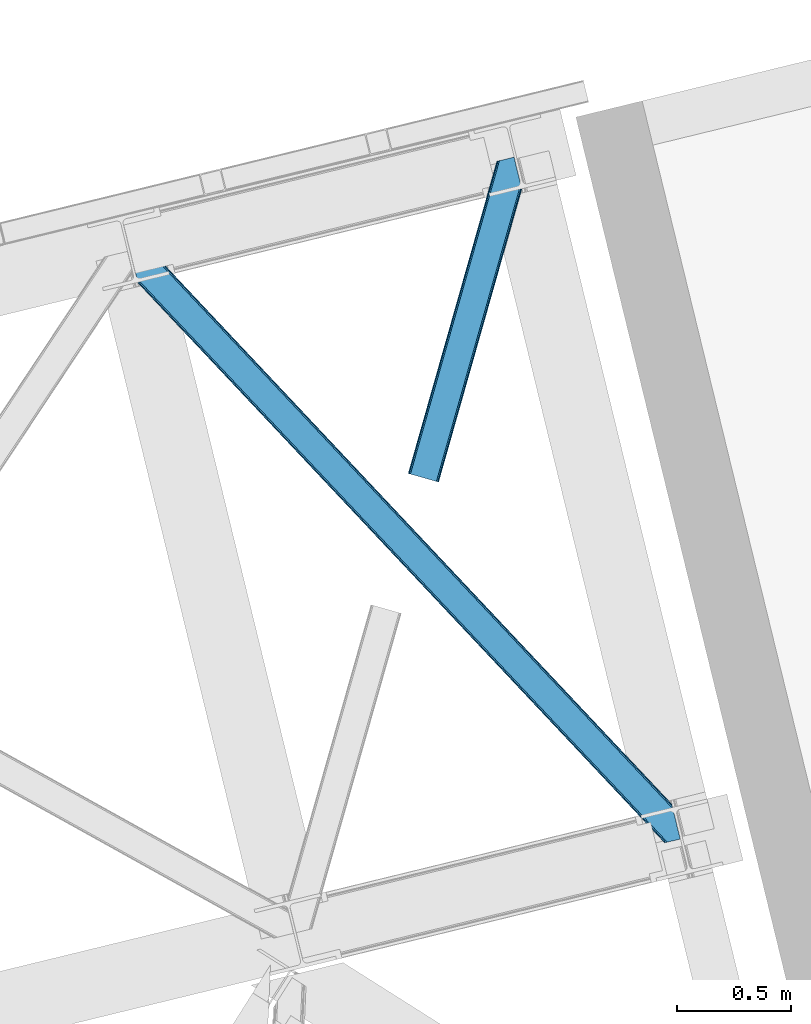
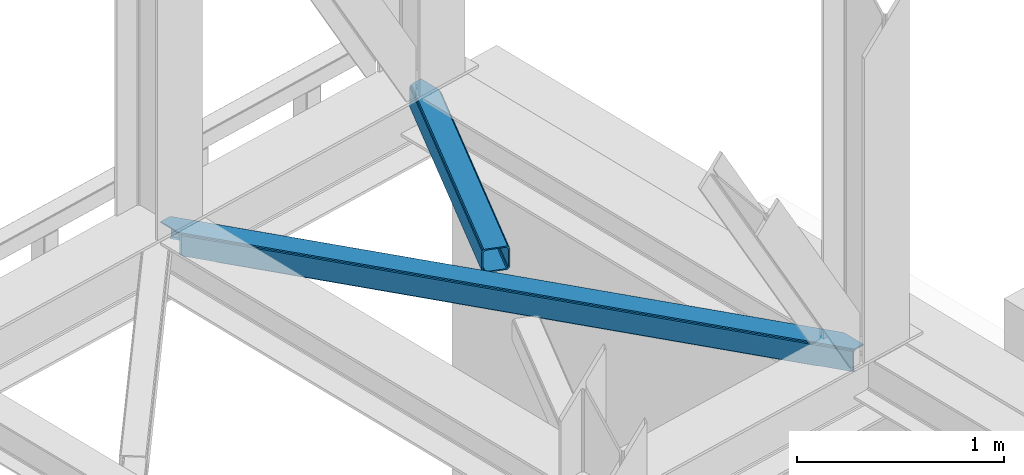
# One storey, part 84 of 93: 2 members.
"""IFC4 building model written with IfcOpenShell, lengths in millimetres."""

from ifc_helpers import new_model, entity, si_unit, converted_unit, derived_unit, direction, frame, origin, place, context, subcontext, project, spatial, triangles, type_object, element, save


model = new_model("IFC4")

# Units and contexts
model_context = context("Model", 3, precision=0.01, world=origin(), true_north=direction((6.12303176911189e-17, 1.0)))
plan_context = context("Plan", 3, precision=0.01, world=origin(), true_north=direction((6.12303176911189e-17, 1.0)))
body_context = subcontext(model_context, "Body", "Model", "MODEL_VIEW")
ifc_project = project(units=[si_unit("LENGTHUNIT", "METRE", prefix="MILLI"), si_unit("AREAUNIT", "SQUARE_METRE"), si_unit("VOLUMEUNIT", "CUBIC_METRE"), converted_unit("PLANEANGLEUNIT", "DEGREE", entity("IfcRatioMeasure", 0.0174532925199433), si_unit("PLANEANGLEUNIT", "RADIAN"), dimensions=[0, 0, 0, 0, 0, 0, 0]), si_unit("MASSUNIT", "GRAM", prefix="KILO"), derived_unit("MASSDENSITYUNIT", [(si_unit("MASSUNIT", "GRAM", prefix="KILO"), 1), (si_unit("LENGTHUNIT", "METRE"), -3)]), derived_unit("MOMENTOFINERTIAUNIT", [(si_unit("LENGTHUNIT", "METRE"), 4)]), si_unit("TIMEUNIT", "SECOND"), si_unit("FREQUENCYUNIT", "HERTZ"), si_unit("THERMODYNAMICTEMPERATUREUNIT", "DEGREE_CELSIUS"), derived_unit("THERMALTRANSMITTANCEUNIT", [(si_unit("MASSUNIT", "GRAM", prefix="KILO"), 1), (si_unit("THERMODYNAMICTEMPERATUREUNIT", "KELVIN"), -1), (si_unit("TIMEUNIT", "SECOND"), -3)]), derived_unit("VOLUMETRICFLOWRATEUNIT", [(si_unit("LENGTHUNIT", "METRE"), 3), (si_unit("TIMEUNIT", "SECOND"), -1)]), derived_unit("MASSFLOWRATEUNIT", [(si_unit("MASSUNIT", "GRAM", prefix="KILO"), 1), (si_unit("TIMEUNIT", "SECOND"), -1)]), derived_unit("ROTATIONALFREQUENCYUNIT", [(si_unit("TIMEUNIT", "SECOND"), -1)]), si_unit("ELECTRICCURRENTUNIT", "AMPERE"), si_unit("ELECTRICVOLTAGEUNIT", "VOLT"), si_unit("POWERUNIT", "WATT"), si_unit("FORCEUNIT", "NEWTON", prefix="KILO"), si_unit("ILLUMINANCEUNIT", "LUX"), si_unit("LUMINOUSFLUXUNIT", "LUMEN"), si_unit("LUMINOUSINTENSITYUNIT", "CANDELA"), derived_unit("USERDEFINED", [(si_unit("MASSUNIT", "GRAM", prefix="KILO"), -1), (si_unit("LENGTHUNIT", "METRE"), -2), (si_unit("TIMEUNIT", "SECOND"), 3), (si_unit("LUMINOUSFLUXUNIT", "LUMEN"), 1)]), derived_unit("LINEARVELOCITYUNIT", [(si_unit("LENGTHUNIT", "METRE"), 1), (si_unit("TIMEUNIT", "SECOND"), -1)]), si_unit("PRESSUREUNIT", "PASCAL"), derived_unit("USERDEFINED", [(si_unit("LENGTHUNIT", "METRE"), -2), (si_unit("MASSUNIT", "GRAM", prefix="KILO"), 1), (si_unit("TIMEUNIT", "SECOND"), -2)]), derived_unit("LINEARFORCEUNIT", [(si_unit("MASSUNIT", "GRAM", prefix="KILO"), 1), (si_unit("LENGTHUNIT", "METRE"), 1), (si_unit("TIMEUNIT", "SECOND"), -2), (si_unit("LENGTHUNIT", "METRE"), -1)]), derived_unit("PLANARFORCEUNIT", [(si_unit("MASSUNIT", "GRAM", prefix="KILO"), 1), (si_unit("LENGTHUNIT", "METRE"), 1), (si_unit("TIMEUNIT", "SECOND"), -2), (si_unit("LENGTHUNIT", "METRE"), -2)])], contexts=[model_context, plan_context])

# Site, building, storey
site_placement = place(None, origin())
site = spatial("IfcSite", under=ifc_project, at=site_placement, CompositionType="ELEMENT")
building_placement = place(site_placement, origin())
building = spatial("IfcBuilding", under=site, at=building_placement, CompositionType="ELEMENT")
storey_placement = place(building_placement, frame((0.0, 0.0, 15900.0)))
storey = spatial("IfcBuildingStorey", under=building, at=storey_placement, CompositionType="ELEMENT", Elevation=15900.0)

# Members
member_type_1 = type_object("IfcMemberType", PredefinedType="BRACE")
member_1_placement = place(storey_placement, frame((-2893.848072052, 17476.1728088379, 3510.01988525391)))
element("IfcMember", 1, at=member_1_placement, inside=storey, type_object=member_type_1, ObjectType="Steel Horizontal Brace", PredefinedType="BRACE", context=body_context, shape_type="Tessellation", body=[
    triangles([(2390.20879182816, 136.983499145506, 140.000756835936), (2386.99318141937, 150.175717163085, 138.668280029298), (56.5227127075195, 2617.59836425781, 140.000756835936), (64.0010353088378, 2619.42150878906, 138.668280029298), (2384.26711235046, 161.358755493166, 134.87548828125), (70.3451248168944, 2620.96792602539, 134.87548828125), (2382.44560289383, 168.831555175781, 129.196765136719), (74.5788780212401, 2622.00042114258, 129.196765136719), (2381.80599803925, 171.455813598634, 122.499499511719), (76.0700660705566, 2622.36318969727, 122.499499511719), (2006.64328708649, 570.234960937501, 17.5000946044929), (2381.80599803925, 171.455813598634, 17.5000946044929), (1617.6124546051, 983.763208007811, 17.5000946044929), (1228.57718925476, 1397.2902923584, 17.5000946044929), (450.510873413086, 2224.3456237793, 17.5000946044929), (76.0700660705566, 2622.36318969727, 17.5000946044929), (839.546284103394, 1810.81853942871, 17.5000946044929), (26.1158477783201, 2496.68248901367, 140.000756835936), (0.0, 2603.82013549805, 140.000756835936), (2370.43223733902, 4.76366271972802, 140.000756835936), (2419.52200984955, 16.7303741455071, 140.000756835936), (2350.88942584991, 0.0, 122.499499511719), (2352.37603569031, 0.362768554688955, 129.196765136719), (34.5188232421874, 2462.2125, 122.499499511719), (33.8790367126462, 2464.83559570312, 129.196765136719), (2356.61443977356, 1.395263671875, 134.87548828125), (32.0576362609863, 2472.30723266601, 134.87548828125), (2362.95402374268, 2.94051818847583, 138.668280029298), (29.3316398620605, 2483.49259643555, 138.668280029298), (1193.06046180725, 1230.72371520996, 17.5000946044929), (1583.89125709534, 815.290933227538, 17.5000946044929), (1974.7174741745, 399.856988525389, 17.5000946044929), (2350.88942584991, 0.0, 17.5000946044929), (802.234317398071, 1646.15765991211, 17.5000946044929), (411.408027648926, 2061.59276733398, 17.5000946044929), (34.5188232421874, 2462.2125, 17.5000946044929), (2364.4315861702, 3.30096130371021, 127.875915527344), (2370.77113380432, 4.84621582031104, 131.668707275392), (2360.19314575195, 2.26730346679688, 122.197192382813), (2378.2538892746, 6.67052307129052, 133.00118408203), (2419.52200984955, 16.7303741455071, 133.00118408203), (2358.70653591156, 1.90569763183521, 115.499926757813), (2358.70653591156, 1.90569763183521, 24.5008300781265), (2360.19314575195, 2.26730346679688, 17.8035644531265), (2352.67877883911, 0.436019897460938, 10.8691040039048), (2353.04928674698, 0.526712036131357, 9.50058288574292), (2364.4315861702, 3.30096130371021, 12.1260040283196), (2368.18651685715, 4.21602172851635, 9.50058288574292), (1982.47063465118, 401.827798461913, 24.5008300781265), (1588.94283828735, 820.135986328125, 24.5008300781265), (1195.4104637146, 1238.44417419434, 24.5008300781265), (31.1576911926268, 2476.00003051758, 115.499926757813), (408.350074768066, 2075.05938720703, 24.5008300781265), (31.1576911926268, 2476.00003051758, 24.5008300781265), (801.882594680786, 1656.75236206055, 24.5008300781265), (25.9705078124998, 2497.28012695313, 131.668707275392), (22.7547157287595, 2510.4723449707, 133.00118408203), (28.6965042114257, 2486.09708862305, 127.875915527344), (30.517904663086, 2478.6231262207, 122.197192382813), (30.3873893737791, 2479.16030273437, 17.8710021972656), (34.5051612854004, 2462.26831054688, 16.5001556396492), (30.22809677124, 2479.8137512207, 16.5001556396492), (0.0, 2603.82013549805, 133.00118408203), (48.7057479858399, 2615.6938293457, 133.00118408203), (2393.56992387772, 123.194805908202, 133.00118408203), (2385.16713008881, 157.66712036133, 115.499926757813), (2385.80673494339, 155.042861938477, 122.197192382813), (66.7619132995605, 2620.09588623047, 122.197192382813), (68.2484504699705, 2620.4563293457, 115.499926757813), (2387.62824440002, 147.570062255858, 127.875915527344), (62.527869415283, 2619.06339111328, 127.875915527344), (2390.35431346893, 136.387023925781, 131.668707275392), (56.1837799072264, 2617.51697387695, 131.668707275392), (1226.23169288635, 1389.57215881348, 24.5008300781265), (1617.96868286133, 973.170831298827, 24.5008300781265), (2009.70560016632, 556.76950378418, 24.5008300781265), (2385.16713008881, 157.66712036133, 24.5008300781265), (834.490197372436, 1805.9723236084, 24.5008300781265), (442.753207397461, 2222.37365112305, 24.5008300781265), (68.2484504699705, 2620.4563293457, 24.5008300781265), (66.7619132995605, 2620.09588623047, 17.8035644531265), (74.2762802124021, 2621.92600708008, 10.8691040039048), (73.9056632995603, 2621.83764038086, 9.50058288574292), (62.527869415283, 2619.06339111328, 12.1260040283196), (58.7728660583493, 2618.14716796875, 9.50058288574292), (2385.9372502327, 154.508010864258, 17.8710021972656), (2386.09654283524, 153.854562377928, 16.5001556396492), (2381.81973266602, 171.398840332033, 16.5001556396492), (41.7939605712891, 2456.42215576172, 10.8039916992202), (36.8073463439941, 2482.3787109375, 9.50058288574292), (34.7757843017575, 2479.63701782226, 12.1260040283196), (43.3136352539063, 2455.68731689453, 9.50058288574292), (170.418958282471, 2340.35482177734, 9.50058288574292), (155.286451721192, 2336.66434936523, 9.50058288574292), (180.780244445801, 2508.2352722168, 9.50058288574292), (187.286533355713, 2481.54155273438, 9.50058288574292), (181.188068389893, 2507.60275268555, 9.25408630371021), (187.878357696533, 2480.72532348633, 9.42384338378906), (181.610426330567, 2506.94930419922, 9.00061340332104), (188.450415802002, 2479.24401855469, 9.11688537597729), (182.028424072265, 2506.29585571289, 8.74597778320458), (189.028287506103, 2477.75573730469, 8.80760192871094), (182.436248016357, 2505.66333618164, 8.50064392089917), (189.60005493164, 2476.27443237305, 8.50064392089917), (2381.54910964966, 154.028970336913, 12.1260040283196), (2374.53078804016, 177.24383239746, 10.8039916992202), (2379.51751127243, 151.288439941407, 9.50058288574292), (2373.01111335754, 177.979833984376, 9.50058288574292), (2233.21012630463, 306.80569152832, 9.50058288574292), (2248.34285087585, 310.495001220705, 9.50058288574292), (2005.67379684448, 569.32222595215, 10.8039916992202), (2002.91328220367, 566.723547363283, 5.12643127441333), (2244.78223972321, 309.626449584961, 5.12643127441333), (449.541455841064, 2223.43405151367, 10.8039916992202), (446.776508331299, 2220.83421020508, 5.12643127441333), (183.700996398926, 2500.47295532226, 5.12643127441333), (442.640714263916, 2216.94375, 1.33247680664135), (186.427283477783, 2489.28991699219, 1.33247680664135), (437.765721130371, 2212.35565795899, 0.0), (189.642784881592, 2476.09769897461, 0.0), (2238.43815021515, 308.080032348633, 1.33247680664135), (2230.95990028381, 306.256887817384, 0.0), (1998.77770614624, 562.833087158204, 1.33247680664135), (1993.89820747375, 558.24383239746, 0.0), (1616.64303703308, 982.850473022459, 10.8039916992202), (1227.60762634277, 1396.37755737305, 10.8039916992202), (838.572215652466, 1809.90464172363, 10.8039916992202), (1613.87794418335, 980.250631713869, 5.12643127441333), (1224.84253349304, 1393.77771606445, 5.12643127441333), (835.811773681641, 1807.30596313476, 5.12643127441333), (1609.74229545593, 976.36017150879, 1.33247680664135), (1220.71153564453, 1389.8884185791, 1.33247680664135), (831.676124954224, 1803.41666564941, 1.33247680664135), (1604.86730232239, 971.772079467773, 0.0), (1215.83203697205, 1385.29916381836, 0.0), (826.796626281738, 1798.82741088867, 0.0), (2008.73153171539, 555.855606079102, 17.8035644531265), (2005.9709444046, 553.256927490234, 12.1260040283196), (439.023202514648, 2218.86223754883, 12.1260040283196), (189.798298645019, 2475.46052856445, 8.41343994140698), (434.887699127197, 2214.97177734375, 8.3320495605476), (193.003916931152, 2462.31016845703, 7.00073547363354), (2001.83544101715, 549.366467285156, 8.3320495605476), (1996.95594234467, 544.777212524416, 7.00073547363354), (2223.14279022217, 304.352352905273, 7.00073547363354), (2230.46741580963, 306.137127685546, 8.81922912597656), (430.008055114746, 2210.38368530274, 7.00073547363354), (441.783789825439, 2221.45975341797, 17.8035644531265), (1610.09852371216, 965.767794799805, 8.3320495605476), (1605.21902503967, 961.178540039062, 7.00073547363354), (1213.4820350647, 1377.57986755371, 7.00073547363354), (1218.36153373718, 1382.16912231445, 8.3320495605476), (821.745045089722, 1793.98119506836, 7.00073547363354), (826.624543762207, 1798.5704498291, 8.3320495605476), (1614.23402709961, 969.658255004884, 12.1260040283196), (1222.49703712463, 1386.05958251953, 12.1260040283196), (830.760192489624, 1802.46091003418, 12.1260040283196), (1616.9946144104, 972.256933593751, 17.8035644531265), (1225.25762443542, 1388.6582611084, 17.8035644531265), (833.520634460449, 1805.05958862305, 17.8035644531265), (219.79792098999, 2352.39129638672, 0.0), (219.79792098999, 2352.39129638672, 7.00073547363354), (173.166464996338, 2341.02454833984, 8.81922912597656), (180.486367034912, 2342.80816040039, 7.00073547363354), (172.669402313232, 2340.90130004883, 0.0), (165.191079711914, 2339.08048095703, 1.33247680664135), (158.846990203857, 2337.5340637207, 5.12643127441333), (424.15317993164, 2073.5827331543, 0.0), (814.97932434082, 1658.14878845215, 0.0), (1205.81011962891, 1242.71600646973, 0.0), (1987.46262645721, 411.846954345703, 0.0), (1596.63640937805, 827.282061767579, 0.0), (2192.71020011902, 296.934201049804, 0.0), (2226.68196372986, 157.568289184572, 0.0), (421.095517730713, 2087.04935302735, 7.00073547363354), (814.627746963501, 1668.74349060059, 7.00073547363354), (1208.15561599731, 1250.43414001465, 7.00073547363354), (1995.22029247284, 413.820089721681, 7.00073547363354), (2192.71020011902, 296.934201049804, 7.00073547363354), (2223.3208316803, 171.356982421876, 7.00073547363354), (1601.68799057007, 832.127114868163, 7.00073547363354), (1975.68703708649, 400.768560791017, 10.8039916992202), (412.377445220947, 2062.50433959961, 10.8039916992202), (415.142683410645, 2065.1041809082, 5.12643127441333), (2235.13660755157, 126.065560913084, 9.25408630371021), (2234.7142496109, 126.717846679687, 9.00061340332104), (2235.54457683563, 125.433041381835, 9.50058288574292), (2234.29632453918, 127.372457885744, 8.74597778320458), (2233.88835525513, 128.004977416993, 8.50064392089917), (1978.45205726624, 403.368402099608, 5.12643127441333), (2232.62367954254, 133.193032836913, 5.12643127441333), (2229.89761047363, 144.376071166993, 1.33247680664135), (1982.58312778473, 407.257699584959, 1.33247680664135), (419.278186798096, 2068.99464111328, 1.33247680664135), (1591.75691070557, 822.692807006835, 1.33247680664135), (1200.93062095642, 1238.12675170898, 1.33247680664135), (810.104331207275, 1653.56069641113, 1.33247680664135), (1587.62126197815, 818.802346801756, 5.12643127441333), (1196.79511756897, 1234.2362915039, 5.12643127441333), (805.968827819824, 1649.67023620605, 5.12643127441333), (1584.86082000732, 816.203668212889, 10.8039916992202), (1194.03453025818, 1231.63761291504, 10.8039916992202), (803.203734970093, 1647.07039489746, 10.8039916992202), (1990.34079380035, 409.230834960938, 8.3320495605476), (2227.21637878418, 155.690496826173, 8.8831787109375), (2226.72454833984, 157.393881225587, 8.50064392089917), (1986.20521774292, 405.340374755859, 12.1260040283196), (2229.03814258575, 152.124435424805, 9.50058288574292), (2228.43301963806, 153.310409545898, 9.2947814941399), (2227.82150173187, 154.503359985352, 9.08898010254052), (2226.52637729645, 158.206622314454, 8.41343994140698), (416.220524597168, 2082.46126098633, 8.3320495605476), (412.084730529785, 2078.5731262207, 12.1260040283196), (409.319783020019, 2075.97328491211, 17.8035644531265), (1983.44470310211, 402.741696166991, 17.8035644531265), (1589.91240119934, 821.048721313477, 17.8035644531265), (1196.38002662659, 1239.35690917969, 17.8035644531265), (802.852157592773, 1657.6650970459, 17.8035644531265), (1592.67284317017, 823.647399902344, 12.1260040283196), (1199.14497413635, 1241.95675048828, 12.1260040283196), (805.612599563598, 1660.26377563476, 12.1260040283196), (1596.80849189758, 827.537860107423, 8.3320495605476), (1203.28062286377, 1245.84604797363, 8.3320495605476), (809.748248291015, 1664.15423583984, 8.3320495605476)], [[1, 2, 3], [4, 3, 2], [2, 5, 4], [6, 4, 5], [5, 7, 6], [8, 6, 7], [7, 9, 8], [10, 8, 9], [11, 9, 12], [9, 11, 13], [9, 14, 10], [14, 9, 13], [15, 16, 10], [17, 10, 14], [10, 17, 15], [3, 18, 1], [3, 19, 18], [20, 1, 18], [21, 1, 20], [22, 23, 24], [25, 24, 23], [23, 26, 25], [27, 25, 26], [26, 28, 27], [29, 27, 28], [28, 20, 29], [18, 29, 20], [30, 22, 24], [22, 31, 32], [30, 31, 22], [32, 33, 22], [34, 24, 35], [24, 34, 30], [36, 35, 24], [37, 38, 28], [26, 37, 28], [37, 26, 23], [39, 37, 23], [39, 23, 22], [38, 20, 28], [21, 40, 41], [21, 20, 40], [38, 40, 20], [39, 22, 42], [43, 33, 44], [22, 43, 42], [33, 45, 44], [22, 33, 43], [46, 47, 45], [47, 44, 45], [48, 47, 46], [49, 42, 43], [42, 49, 50], [42, 51, 52], [51, 42, 50], [53, 54, 52], [55, 52, 51], [52, 55, 53], [40, 38, 56], [56, 57, 40], [38, 37, 58], [58, 56, 38], [37, 39, 59], [59, 58, 37], [39, 42, 52], [52, 59, 39], [60, 61, 62], [24, 36, 54], [36, 60, 54], [54, 52, 24], [36, 61, 60], [59, 24, 52], [25, 24, 59], [27, 59, 58], [59, 27, 25], [58, 29, 27], [56, 29, 58], [56, 57, 18], [56, 18, 29], [57, 19, 18], [57, 63, 19], [57, 64, 65], [64, 57, 63], [65, 40, 57], [41, 40, 65], [66, 67, 68], [68, 69, 66], [67, 70, 71], [71, 68, 67], [70, 72, 73], [73, 71, 70], [72, 65, 64], [64, 73, 72], [74, 66, 69], [66, 75, 76], [74, 75, 66], [76, 77, 66], [78, 69, 79], [69, 78, 74], [80, 79, 69], [71, 73, 4], [6, 71, 4], [71, 6, 8], [68, 71, 8], [68, 8, 10], [73, 3, 4], [19, 64, 63], [19, 3, 64], [73, 64, 3], [68, 10, 69], [80, 16, 81], [10, 80, 69], [16, 82, 81], [10, 16, 80], [83, 84, 82], [84, 81, 82], [85, 84, 83], [70, 5, 2], [65, 72, 1], [72, 70, 2], [86, 87, 88], [41, 65, 21], [1, 21, 65], [72, 2, 1], [86, 12, 77], [9, 66, 77], [77, 12, 9], [86, 88, 12], [9, 67, 66], [67, 5, 70], [5, 67, 7], [9, 7, 67], [89, 90, 91], [89, 92, 90], [91, 61, 89], [62, 61, 91], [92, 90, 93], [93, 94, 92], [85, 83, 95], [95, 96, 85], [97, 98, 96], [99, 100, 98], [101, 102, 100], [103, 104, 102], [102, 101, 103], [100, 99, 101], [98, 97, 99], [96, 95, 97], [88, 105, 106], [105, 88, 87], [107, 106, 105], [107, 108, 106], [109, 110, 108], [108, 107, 109], [12, 88, 106], [111, 106, 110], [110, 112, 111], [110, 113, 112], [106, 108, 110], [114, 101, 99], [101, 114, 103], [114, 97, 95], [97, 114, 99], [95, 82, 114], [95, 83, 82], [114, 115, 116], [116, 103, 114], [114, 82, 16], [16, 15, 114], [115, 117, 118], [118, 116, 115], [117, 119, 120], [120, 118, 117], [121, 122, 123], [124, 123, 122], [113, 121, 112], [123, 112, 121], [12, 106, 11], [111, 11, 106], [11, 111, 13], [125, 13, 111], [13, 125, 14], [126, 14, 125], [14, 126, 127], [127, 17, 14], [17, 127, 15], [114, 15, 127], [111, 112, 128], [128, 125, 111], [125, 128, 126], [129, 126, 128], [126, 129, 127], [130, 127, 129], [127, 130, 115], [115, 114, 127], [112, 123, 131], [131, 128, 112], [128, 131, 132], [132, 129, 128], [129, 132, 130], [133, 130, 132], [130, 133, 115], [117, 115, 133], [123, 124, 134], [134, 131, 123], [131, 134, 135], [135, 132, 131], [132, 135, 136], [136, 133, 132], [133, 136, 119], [119, 117, 133], [137, 138, 105], [105, 87, 137], [137, 86, 77], [139, 104, 140], [102, 139, 100], [102, 104, 139], [98, 100, 139], [96, 139, 84], [84, 85, 96], [96, 98, 139], [141, 140, 142], [143, 144, 145], [138, 143, 146], [146, 109, 138], [107, 105, 109], [138, 109, 105], [145, 146, 143], [142, 147, 141], [140, 141, 139], [139, 148, 81], [81, 84, 139], [148, 79, 80], [80, 81, 148], [77, 76, 137], [87, 86, 137], [144, 143, 149], [149, 150, 144], [150, 149, 151], [152, 151, 149], [151, 152, 153], [154, 153, 152], [153, 154, 147], [141, 147, 154], [143, 138, 155], [155, 149, 143], [149, 155, 156], [156, 152, 149], [152, 156, 157], [157, 154, 152], [154, 157, 141], [139, 141, 157], [138, 137, 155], [158, 155, 137], [155, 158, 156], [159, 156, 158], [156, 159, 160], [160, 157, 156], [157, 160, 148], [148, 139, 157], [137, 76, 75], [75, 158, 137], [158, 75, 74], [74, 159, 158], [159, 74, 160], [78, 160, 74], [160, 78, 148], [79, 148, 78], [104, 120, 140], [118, 104, 116], [104, 118, 120], [104, 103, 116], [140, 120, 142], [142, 161, 162], [161, 142, 120], [163, 164, 165], [93, 165, 166], [166, 167, 93], [161, 164, 162], [164, 161, 165], [167, 94, 93], [165, 93, 163], [168, 165, 161], [119, 168, 161], [119, 161, 120], [136, 168, 119], [169, 168, 136], [135, 169, 136], [169, 135, 170], [124, 171, 172], [170, 134, 172], [134, 170, 135], [134, 124, 172], [124, 173, 171], [171, 173, 174], [122, 173, 124], [153, 147, 175], [175, 176, 153], [176, 151, 153], [151, 176, 177], [147, 164, 175], [162, 147, 142], [147, 162, 164], [145, 144, 178], [178, 179, 145], [179, 178, 180], [144, 181, 178], [150, 177, 181], [177, 150, 151], [144, 150, 181], [146, 145, 122], [109, 122, 121], [121, 113, 109], [173, 145, 179], [145, 173, 122], [113, 110, 109], [122, 109, 146], [182, 45, 33], [36, 61, 89], [183, 89, 94], [94, 184, 183], [94, 167, 184], [89, 92, 94], [185, 182, 186], [185, 187, 182], [182, 188, 186], [182, 189, 188], [187, 45, 182], [187, 46, 45], [182, 190, 191], [191, 189, 182], [192, 191, 190], [190, 193, 192], [174, 192, 193], [193, 171, 174], [168, 194, 165], [166, 165, 194], [194, 184, 166], [167, 166, 184], [183, 35, 89], [36, 89, 35], [33, 32, 182], [171, 193, 195], [195, 172, 171], [172, 195, 196], [196, 170, 172], [170, 196, 197], [197, 169, 170], [169, 197, 194], [194, 168, 169], [193, 190, 195], [198, 195, 190], [195, 198, 196], [199, 196, 198], [196, 199, 197], [200, 197, 199], [197, 200, 194], [184, 194, 200], [190, 182, 201], [201, 198, 190], [198, 201, 202], [202, 199, 198], [199, 202, 200], [203, 200, 202], [200, 203, 183], [183, 184, 200], [182, 32, 201], [31, 201, 32], [201, 31, 30], [30, 202, 201], [202, 30, 34], [34, 203, 202], [203, 34, 35], [35, 183, 203], [204, 205, 206], [207, 208, 209], [209, 204, 207], [209, 210, 204], [205, 204, 210], [206, 211, 204], [47, 48, 208], [208, 207, 47], [204, 211, 180], [212, 175, 164], [213, 212, 163], [163, 93, 213], [214, 213, 91], [91, 62, 214], [214, 60, 54], [54, 53, 214], [62, 60, 214], [213, 93, 91], [90, 91, 93], [164, 163, 212], [180, 178, 204], [44, 47, 207], [207, 215, 44], [43, 44, 215], [215, 49, 43], [49, 215, 50], [216, 50, 215], [50, 216, 51], [217, 51, 216], [51, 217, 218], [218, 55, 51], [55, 218, 53], [214, 53, 218], [215, 207, 219], [219, 216, 215], [216, 219, 220], [220, 217, 216], [217, 220, 218], [221, 218, 220], [218, 221, 214], [213, 214, 221], [207, 204, 219], [222, 219, 204], [219, 222, 220], [223, 220, 222], [220, 223, 224], [224, 221, 220], [221, 224, 212], [212, 213, 221], [204, 178, 222], [181, 222, 178], [222, 181, 223], [177, 223, 181], [223, 177, 224], [176, 224, 177], [224, 176, 212], [175, 212, 176], [174, 211, 206], [179, 180, 173], [180, 211, 174], [174, 173, 180], [192, 174, 206], [206, 189, 191], [191, 192, 206], [189, 206, 205], [188, 205, 210], [186, 210, 209], [185, 209, 208], [208, 187, 185], [209, 185, 186], [210, 186, 188], [205, 188, 189], [187, 208, 48], [48, 46, 187]]),
])
member_type_2 = type_object("IfcMemberType", PredefinedType="BRACE")
member_2_placement = place(storey_placement, frame((-1671.07256355286, 19062.4736572266, 3510.01988525391)))
element("IfcMember", 2, at=member_2_placement, inside=storey, type_object=member_type_2, ObjectType="Steel Horizontal Brace", PredefinedType="BRACE", context=body_context, shape_type="Tessellation", body=[
    triangles([(500.301584243774, 1287.51443481445, 17.5000946044929), (500.301584243774, 1287.51443481445, 122.499499511719), (134.676372528076, 0.0, 17.5000946044929), (134.676372528076, 0.0, 122.499499511719), (495.114400863647, 1308.79453125, 138.668280029298), (491.898754119873, 1321.98674926758, 140.000756835936), (117.842952346802, 4.77994079589553, 140.000756835936), (124.282530212402, 2.94981994628688, 138.668280029298), (497.840469932556, 1297.61149291992, 134.87548828125), (129.74440612793, 1.39991455078052, 134.87548828125), (499.662015724182, 1290.13985595703, 129.196765136719), (133.395636749268, 0.363931274412607, 129.196765136719), (16.8379257202148, 33.4642364501924, 140.000756835936), (409.260048294067, 1415.34616699219, 140.000756835936), (465.782761001587, 1429.12439575195, 140.000756835936), (391.19923210144, 1410.94411010742, 129.196765136719), (389.71269493103, 1410.58134155273, 122.499499511719), (1.28073577880855, 37.880245971679, 129.196765136719), (0.0, 38.2441772460916, 122.499499511719), (395.437636184692, 1411.97660522461, 134.87548828125), (4.93196640014662, 36.844262695311, 134.87548828125), (401.777220153809, 1413.52302246094, 138.668280029298), (10.393842315674, 35.2931945800774, 138.668280029298), (389.71269493103, 1410.58134155273, 17.5000946044929), (0.0, 38.2441772460916, 17.5000946044929), (1.28073577880855, 37.880245971679, 10.8039916992202), (391.19923210144, 1410.94411010742, 10.8039916992202), (350.625400543213, 1255.50010986328, 5.50082702636792), (4.93196640014662, 36.844262695311, 5.12643127441333), (350.610866546631, 1254.51877441406, 5.25316772460792), (395.030974960327, 1411.87893676758, 5.50082702636792), (350.591681671143, 1253.51883544922, 5.00085754394604), (10.393842315674, 35.2931945800774, 1.33247680664135), (350.577002334595, 1252.51657104492, 4.74854736328052), (350.562613677979, 1251.53756103515, 4.50088806152417), (352.972204971313, 1241.65211791992, 1.33247680664135), (356.187851715088, 1228.45989990234, 0.0), (16.8379257202148, 33.4642364501924, 0.0), (386.342987823486, 1104.751171875, 0.0), (117.842952346802, 4.77994079589553, 0.0), (433.47165184021, 1116.23884277344, 0.0), (447.69621963501, 1119.70607299804, 5.50082702636792), (440.949974441528, 1118.06198730469, 1.33247680664135), (387.314440155029, 1104.98836669922, 5.50082702636792), (386.342987823486, 1104.751171875, 4.50088806152417), (498.721520805359, 1286.82843017578, 10.8039916992202), (133.395636749268, 0.363931274412607, 10.8039916992202), (129.74440612793, 1.39991455078052, 5.12643127441333), (124.282530212402, 2.94981994628688, 1.33247680664135), (494.138297653198, 1283.24260253906, 5.50082702636792), (499.951314926147, 1288.95155639648, 12.5003997802742), (458.982304000855, 1427.46635742187, 5.50082702636792), (494.653818511963, 1310.68511352539, 12.5003997802742), (489.445488166809, 1314.45465087891, 8.3320495605476), (485.489479637146, 1325.04702758789, 7.00073547363354), (460.437302398682, 1427.8221496582, 7.00073547363354), (23.5703636169435, 31.5515624999971, 7.00073547363354), (417.077158355713, 1417.2507019043, 7.00073547363354), (111.110514450073, 6.69261474609084, 7.00073547363354), (496.300883674622, 1303.92738647461, 17.8035644531265), (123.011968231201, 3.31258850097583, 12.1260040283196), (126.663198852539, 2.27660522460792, 17.8035644531265), (496.940452194214, 1301.30429077148, 24.5008300781265), (127.943934631348, 1.91151123046802, 24.5008300781265), (117.550092315674, 4.86249389648219, 8.3320495605476), (496.940452194214, 1301.30429077148, 115.499926757813), (127.943934631348, 1.91151123046802, 115.499926757813), (496.300883674622, 1303.92738647461, 122.197192382813), (494.479337882996, 1311.3990234375, 127.875915527344), (491.75334148407, 1322.58206176758, 131.668707275392), (488.537622070313, 1335.77427978515, 133.00118408203), (465.782761001587, 1429.12439575195, 133.00118408203), (126.663198852539, 2.27660522460792, 122.197192382813), (123.011968231201, 3.31258850097583, 127.875915527344), (117.550092315674, 4.86249389648219, 131.668707275392), (111.110514450073, 6.69261474609084, 133.00118408203), (23.5703636169435, 31.5515624999971, 133.00118408203), (417.077158355713, 1417.2507019043, 133.00118408203), (11.6645496368408, 34.9315887451157, 127.875915527344), (17.1264255523681, 33.3805206298821, 131.668707275392), (6.73694343566899, 36.3326660156235, 115.499926757813), (8.01767921447754, 35.9687347412109, 122.197192382813), (11.6645496368408, 34.9315887451157, 12.1260040283196), (17.1264255523681, 33.3805206298821, 8.3320495605476), (6.73694343566899, 36.3326660156235, 24.5008300781265), (8.01767921447754, 35.9687347412109, 17.8035644531265), (409.598835754394, 1415.4298828125, 131.668707275392), (403.254746246338, 1413.88346557617, 127.875915527344), (399.020847702026, 1412.85097045898, 122.197192382813), (397.529804992676, 1412.48587646484, 115.499926757813), (409.598835754394, 1415.4298828125, 8.3320495605476), (399.020847702026, 1412.85097045898, 17.8035644531265), (403.254746246338, 1413.88346557617, 12.1260040283196), (397.529804992676, 1412.48587646484, 24.5008300781265)], [[1, 2, 3], [4, 3, 2], [5, 6, 7], [7, 8, 5], [9, 5, 8], [8, 10, 9], [11, 9, 10], [10, 12, 11], [2, 11, 12], [12, 4, 2], [13, 6, 14], [13, 7, 6], [6, 15, 14], [16, 17, 18], [19, 18, 17], [20, 16, 21], [18, 21, 16], [22, 20, 23], [21, 23, 20], [14, 22, 13], [23, 13, 22], [17, 24, 19], [25, 19, 24], [26, 27, 28], [28, 29, 26], [28, 30, 29], [27, 31, 28], [32, 33, 29], [32, 34, 33], [35, 33, 34], [35, 36, 33], [36, 37, 33], [38, 33, 37], [24, 27, 26], [26, 25, 24], [39, 38, 37], [40, 39, 41], [39, 40, 38], [41, 42, 43], [41, 39, 44], [41, 44, 42], [44, 39, 45], [30, 28, 44], [34, 32, 44], [35, 34, 45], [37, 35, 45], [37, 36, 35], [45, 39, 37], [46, 1, 3], [3, 47, 46], [48, 49, 43], [47, 48, 42], [50, 46, 42], [47, 42, 46], [43, 42, 48], [41, 43, 49], [49, 40, 41], [46, 51, 1], [42, 28, 50], [42, 44, 28], [31, 50, 28], [52, 50, 31], [53, 50, 54], [51, 46, 53], [53, 46, 50], [55, 50, 52], [50, 55, 54], [52, 56, 55], [57, 55, 58], [57, 59, 55], [55, 56, 58], [60, 53, 61], [61, 62, 60], [63, 60, 62], [62, 64, 63], [54, 55, 59], [59, 65, 54], [53, 54, 65], [65, 61, 53], [66, 63, 67], [64, 67, 63], [60, 51, 53], [2, 1, 63], [1, 60, 63], [63, 66, 2], [1, 51, 60], [68, 2, 66], [11, 2, 68], [9, 68, 69], [68, 9, 11], [69, 5, 9], [70, 5, 69], [70, 71, 6], [70, 6, 5], [71, 15, 6], [71, 72, 15], [68, 66, 73], [67, 73, 66], [69, 68, 74], [73, 74, 68], [70, 69, 75], [74, 75, 69], [71, 70, 76], [75, 76, 70], [77, 71, 76], [71, 77, 78], [72, 71, 78], [12, 74, 73], [67, 3, 4], [12, 73, 4], [12, 10, 74], [73, 67, 4], [74, 10, 8], [76, 7, 13], [7, 75, 8], [75, 7, 76], [75, 74, 8], [47, 61, 48], [64, 3, 67], [3, 62, 47], [62, 3, 64], [47, 62, 61], [40, 59, 38], [49, 48, 61], [61, 65, 49], [65, 59, 40], [40, 49, 65], [79, 23, 21], [13, 77, 76], [13, 80, 77], [80, 13, 23], [79, 80, 23], [81, 19, 25], [18, 82, 79], [21, 18, 79], [82, 18, 19], [81, 82, 19], [33, 83, 29], [38, 59, 57], [57, 84, 38], [84, 83, 33], [33, 38, 84], [26, 29, 83], [25, 85, 81], [86, 25, 26], [25, 86, 85], [86, 26, 83], [22, 14, 87], [15, 78, 14], [78, 15, 72], [78, 87, 14], [88, 22, 87], [88, 20, 22], [16, 88, 89], [88, 16, 20], [17, 89, 90], [89, 17, 16], [58, 31, 91], [92, 93, 27], [93, 91, 31], [58, 52, 31], [52, 58, 56], [94, 92, 24], [27, 24, 92], [17, 94, 24], [94, 17, 90], [93, 31, 27], [87, 78, 77], [77, 80, 87], [88, 87, 80], [80, 79, 88], [89, 88, 79], [79, 82, 89], [90, 89, 82], [82, 81, 90], [94, 90, 85], [81, 85, 90], [92, 94, 86], [85, 86, 94], [93, 92, 83], [86, 83, 92], [91, 93, 84], [83, 84, 93], [58, 91, 57], [84, 57, 91]]),
])

save(model, "model.ifc")
